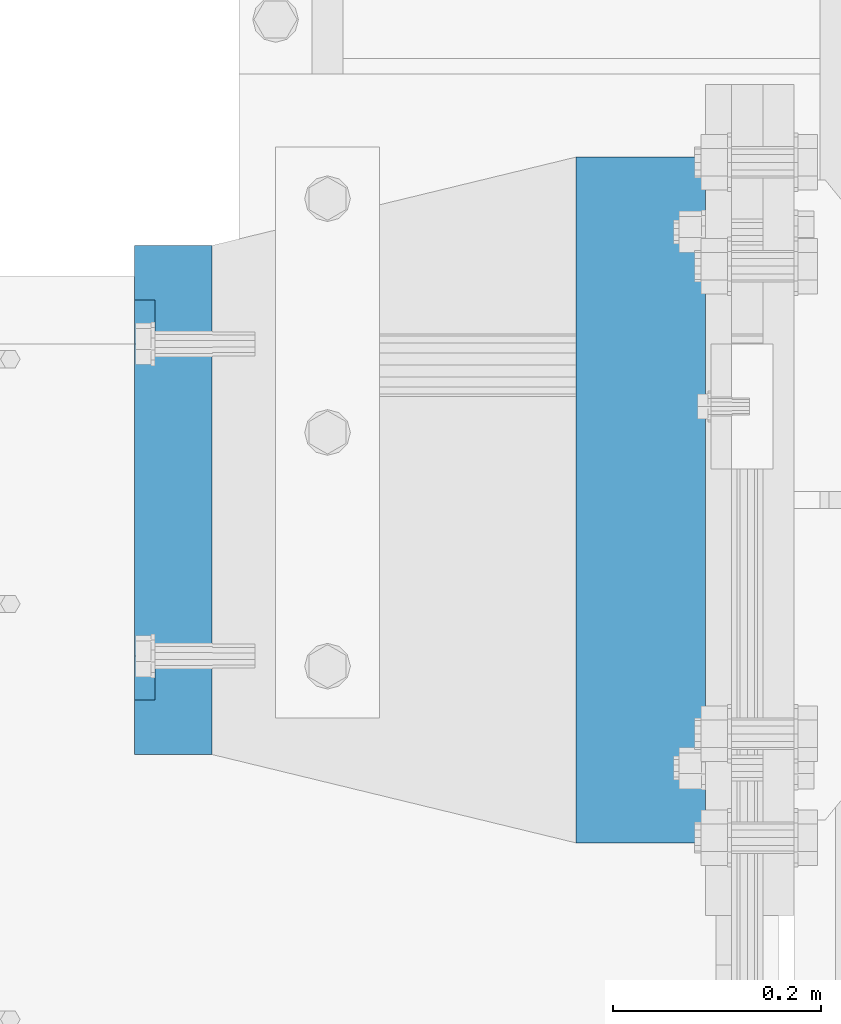
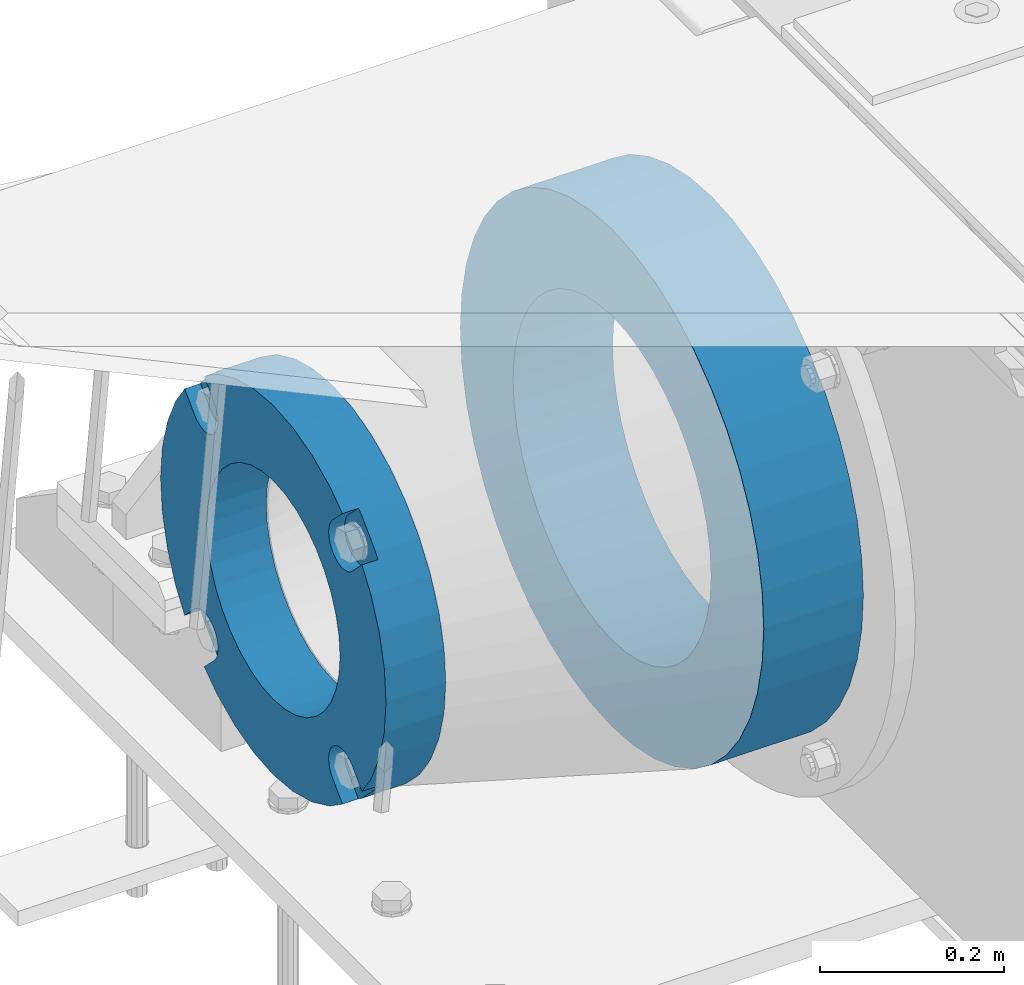
# One storey, part 161 of 270: 2 beams.
"""IFC2X3 building model written with IfcOpenShell, lengths in millimetres."""

from ifc_helpers import new_model, si_unit, frame, origin_with_axes, place, context, subcontext, project, spatial, faceted_brep, material, type_object, element, save


model = new_model("IFC2X3")

# Units and contexts
model_context = context("Model", 3, precision=1e-05, world=origin_with_axes())
body_context = subcontext(model_context, "Body", "Model", "MODEL_VIEW")
ifc_project = project(units=[si_unit("LENGTHUNIT", "METRE", prefix="MILLI"), si_unit("AREAUNIT", "SQUARE_METRE"), si_unit("VOLUMEUNIT", "CUBIC_METRE"), si_unit("MASSUNIT", "GRAM", prefix="KILO"), si_unit("TIMEUNIT", "SECOND"), si_unit("PLANEANGLEUNIT", "RADIAN"), si_unit("SOLIDANGLEUNIT", "STERADIAN"), si_unit("THERMODYNAMICTEMPERATUREUNIT", "DEGREE_CELSIUS"), si_unit("LUMINOUSINTENSITYUNIT", "LUMEN")], contexts=[model_context])

# Site, building, storey
site_placement = place(None, origin_with_axes())
site = spatial("IfcSite", under=ifc_project, at=site_placement, CompositionType="ELEMENT")
building_placement = place(site_placement, origin_with_axes())
building = spatial("IfcBuilding", under=site, at=building_placement, Name="Standard", CompositionType="ELEMENT")
storey_placement = place(building_placement, origin_with_axes())
storey = spatial("IfcBuildingStorey", under=building, at=storey_placement, Name="Undefined", CompositionType="ELEMENT", Elevation=0.0)

# Beams
ifc_material_1 = material(Name="SCN-500-E2")
beam_type_1 = type_object("IfcBeamType", PredefinedType="NOTDEFINED")
beam_1_placement = place(storey_placement, frame((-550.0, -14999.9999985338, -515.0), z_axis=(0.0, 0.0, 1.0), x_axis=(-1.0, 0.0, 0.0)))
element("IfcBeam", 1, at=beam_1_placement, inside=storey, type_object=beam_type_1, material=ifc_material_1, context=body_context, shape_type="Brep", body=[
    faceted_brep([(75.0, 192.717024793295, -150.290616455865), (75.0, 171.473395903973, -129.046987566545), (55.0000000000002, 171.473395903973, -129.046987566545), (55.0000000000002, 192.717024793295, -150.290616455866), (75.0, 167.467485558907, -125.685629673472), (55.0000000000002, 167.467485558907, -125.685629673472), (75.0, 162.938740320598, -123.070957391042), (55.0000000000002, 162.938740320598, -123.070957391042), (75.0, 158.024763821453, -121.282416213469), (55.0000000000002, 158.024763821453, -121.282416213469), (75.0, 152.874864750807, -120.374350059389), (55.0000000000002, 152.874864750807, -120.374350059389), (75.0, 147.645520185946, -120.374350059389), (55.0000000000002, 147.645520185946, -120.374350059389), (75.0, 142.4956211153, -121.282416213469), (55.0000000000002, 142.4956211153, -121.282416213469), (75.0, 137.581644616155, -123.070957391042), (55.0000000000002, 137.581644616155, -123.070957391042), (75.0, 133.052899377846, -125.685629673472), (55.0000000000002, 133.052899377846, -125.685629673472), (75.0, 129.04698903278, -129.046987566545), (55.0000000000002, 129.04698903278, -129.046987566545), (75.0, 125.685631139708, -133.05289791161), (55.0000000000002, 125.685631139708, -133.05289791161), (75.0, 123.070958857277, -137.581643149921), (55.0000000000002, 123.070958857277, -137.581643149921), (75.0, 121.282417679704, -142.495619649066), (55.0000000000002, 121.282417679704, -142.495619649066), (75.0, 120.374351525625, -147.645518719712), (55.0000000000002, 120.374351525625, -147.645518719712), (75.0, 120.374351525625, -152.874863284571), (55.0000000000002, 120.374351525625, -152.874863284571), (75.0, 121.282417679706, -158.024762355217), (55.0000000000002, 121.282417679706, -158.024762355217), (75.0, 123.070958857277, -162.938738854362), (55.0000000000002, 123.070958857277, -162.938738854362), (75.0, 125.685631139708, -167.467484092673), (55.0000000000002, 125.685631139708, -167.467484092673), (75.0, 129.04698903278, -171.473394437738), (55.0000000000002, 129.04698903278, -171.473394437738), (55.0000000000002, 150.290618180639, -192.717023585596), (75.0, 150.290618180637, -192.717023585598), (55.0000000000002, 157.482964373203, -187.68088856415), (55.0000000000002, 187.680888564149, -157.482964373202), (75.0, -192.717023585596, 150.290618180639), (75.0000000000001, -171.4733929715, 129.046987566544), (55.0000000000002, -171.4733929715, 129.046987566544), (55.0000000000002, -192.717023585596, 150.290618180638), (75.0000000000001, -167.467482626435, 125.68562967347), (55.0000000000002, -167.467482626435, 125.68562967347), (75.0000000000001, -162.938737388125, 123.070957391041), (55.0000000000002, -162.938737388125, 123.070957391041), (75.0000000000001, -158.02476088898, 121.282416213468), (55.0000000000002, -158.02476088898, 121.282416213468), (75.0000000000001, -152.874861818334, 120.374350059388), (55.0000000000002, -152.874861818334, 120.374350059388), (75.0000000000001, -147.645517253473, 120.374350059388), (55.0000000000002, -147.645517253473, 120.374350059388), (75.0000000000001, -142.495618182829, 121.282416213468), (55.0000000000002, -142.495618182829, 121.282416213468), (75.0000000000001, -137.581641683682, 123.070957391041), (55.0000000000002, -137.581641683682, 123.070957391041), (75.0000000000001, -133.052896445373, 125.685629673471), (55.0000000000002, -133.052896445373, 125.685629673471), (75.0000000000001, -129.046986100308, 129.046987566544), (55.0000000000002, -129.046986100308, 129.046987566544), (75.0000000000001, -125.685628207235, 133.052897911609), (55.0000000000002, -125.685628207235, 133.052897911609), (75.0000000000001, -123.070955924804, 137.581643149919), (55.0000000000002, -123.070955924804, 137.581643149919), (75.0000000000001, -121.282414747231, 142.495619649065), (55.0000000000002, -121.282414747231, 142.495619649065), (75.0000000000001, -120.374348593152, 147.645518719711), (55.0000000000002, -120.374348593152, 147.645518719711), (75.0000000000001, -120.374348593152, 152.87486328457), (55.0000000000002, -120.374348593152, 152.87486328457), (75.0000000000001, -121.282414747231, 158.024762355216), (55.0000000000002, -121.282414747231, 158.024762355216), (75.0000000000001, -123.070955924804, 162.938738854361), (55.0000000000002, -123.070955924804, 162.938738854361), (75.0000000000001, -125.685628207235, 167.467484092672), (55.0000000000002, -125.685628207235, 167.467484092672), (75.0000000000001, -129.046986100308, 171.473394437737), (55.0000000000002, -129.046986100308, 171.473394437737), (55.0000000000002, -150.290616455866, 192.717024793296), (75.0, -150.290616455866, 192.717024793296), (75.0, 150.290618180637, 192.717023585597), (75.0, 129.04698903278, 171.473394437739), (55.0000000000002, 129.04698903278, 171.473394437739), (55.0000000000002, 150.290618180637, 192.717023585597), (75.0, 125.685631139708, 167.467484092674), (55.0000000000002, 125.685631139708, 167.467484092674), (75.0, 123.070958857277, 162.938738854364), (55.0000000000002, 123.070958857277, 162.938738854364), (75.0, 121.282417679704, 158.024762355218), (55.0000000000002, 121.282417679704, 158.024762355218), (75.0, 120.374351525625, 152.874863284573), (55.0000000000002, 120.374351525625, 152.874863284573), (75.0, 120.374351525625, 147.645518719713), (55.0000000000002, 120.374351525625, 147.645518719713), (75.0, 121.282417679704, 142.495619649067), (55.0000000000002, 121.282417679704, 142.495619649067), (75.0, 123.070958857277, 137.581643149922), (55.0000000000002, 123.070958857277, 137.581643149922), (75.0, 125.685631139708, 133.052897911611), (55.0000000000002, 125.685631139708, 133.052897911611), (75.0, 129.04698903278, 129.046987566546), (55.0000000000002, 129.04698903278, 129.046987566546), (75.0, 133.052899377846, 125.685629673473), (55.0000000000002, 133.052899377846, 125.685629673473), (75.0, 137.581644616155, 123.070957391043), (55.0000000000002, 137.581644616155, 123.070957391043), (75.0, 142.4956211153, 121.282416213471), (55.0000000000002, 142.4956211153, 121.282416213471), (75.0, 147.645520185946, 120.37435005939), (55.0000000000002, 147.645520185946, 120.37435005939), (75.0, 152.874864750807, 120.37435005939), (55.0000000000002, 152.874864750807, 120.37435005939), (75.0000000000001, 158.024763821453, 121.282416213471), (55.0000000000002, 158.024763821453, 121.282416213471), (75.0000000000001, 162.938740320598, 123.070957391043), (55.0000000000002, 162.938740320598, 123.070957391043), (75.0000000000001, 167.467485558907, 125.685629673473), (55.0000000000002, 167.467485558907, 125.685629673473), (75.0000000000001, 171.473395903973, 129.046987566546), (55.0000000000002, 171.473395903973, 129.046987566546), (55.0000000000002, 192.717024793294, 150.290616455866), (75.0, 192.717024793295, 150.290616455867), (0.0, 212.176223927188, -122.5), (0.0, 230.224692092548, -83.7949351147888), (75.0, 230.224692092548, -83.7949351147888), (75.0, 212.176223927188, -122.5), (0.0, 241.277899487992, -42.5438035283978), (75.0, 241.277899487992, -42.5438035283978), (0.0, 245.0, 0.0), (75.0, 245.0, 0.0), (0.0, 241.277899487992, 42.543803528398), (75.0, 241.277899487992, 42.543803528398), (0.0, 230.224692092548, 83.7949351147889), (75.0, 230.224692092548, 83.7949351147889), (0.0, 212.176223927188, 122.5), (75.0, 212.176223927188, 122.5), (0.0, 187.680888564149, 157.482964373202), (55.0000000000002, 187.680888564149, 157.482964373202), (0.0, 157.482964373203, 187.68088856415), (55.0000000000002, 157.482964373203, 187.68088856415), (0.0, 122.5, 212.176223927187), (75.0, 122.5, 212.176223927187), (0.0, 83.794935114789, 230.224692092548), (75.0, 83.794935114789, 230.224692092548), (0.0, 42.5438035283987, 241.277899487991), (75.0, 42.5438035283987, 241.277899487991), (0.0, 0.0, 245.0), (75.0, 0.0, 245.0), (0.0, -42.5438035283987, 241.277899487991), (75.0, -42.5438035283987, 241.277899487991), (0.0, -83.794935114789, 230.224692092548), (75.0, -83.794935114789, 230.224692092548), (0.0, -122.5, 212.176223927187), (75.0, -122.5, 212.176223927187), (0.0, -157.482964373203, 187.68088856415), (55.0000000000002, -157.482964373203, 187.68088856415), (0.0, -187.680888564149, 157.482964373202), (55.0000000000002, -187.680888564149, 157.482964373202), (0.0, -212.176223927188, 122.5), (75.0, -212.176223927188, 122.5), (0.0, -230.224692092548, 83.7949351147888), (75.0, -230.224692092548, 83.7949351147888), (0.0, -241.277899487992, 42.5438035283979), (75.0, -241.277899487992, 42.5438035283979), (0.0, -245.0, 0.0), (75.0, -245.0, 0.0), (0.0, -187.680888564149, -157.482964373202), (0.0, -157.482964373203, -187.68088856415), (55.0000000000002, -157.482964373203, -187.68088856415), (55.0000000000002, -187.680888564149, -157.482964373202), (0.0, 83.794935114789, -230.224692092547), (0.0, 122.5, -212.176223927187), (75.0, 122.5, -212.176223927187), (75.0, 83.794935114789, -230.224692092547), (0.0, 42.5438035283987, -241.277899487991), (75.0, 42.5438035283987, -241.277899487991), (0.0, 0.0, -245.0), (75.0, 0.0, -245.0), (0.0, -42.5438035283987, -241.277899487991), (75.0, -42.5438035283987, -241.277899487991), (0.0, -83.794935114789, -230.224692092548), (75.0, -83.794935114789, -230.224692092548), (0.0, -122.5, -212.176223927187), (75.0, -122.5, -212.176223927187), (75.0, -150.290616455866, -192.717024793296), (55.0000000000002, -150.290616455866, -192.717024793297), (55.0000000000002, -129.046986100308, -171.473394437739), (55.0000000000002, -125.685628207235, -167.467484092674), (55.0000000000002, -123.070955924804, -162.938738854364), (55.0000000000002, -121.282414747233, -158.024762355219), (55.0000000000002, -120.374348593152, -152.874863284573), (55.0000000000002, -120.374348593152, -147.645518719713), (55.0000000000002, -121.282414747233, -142.495619649067), (55.0000000000002, -123.070955924804, -137.581643149922), (55.0000000000002, -125.685628207235, -133.052897911612), (55.0000000000002, -129.046986100308, -129.046987566547), (55.0000000000002, -133.052896445373, -125.685629673473), (55.0000000000002, -137.581641683682, -123.070957391043), (55.0000000000002, -142.495618182827, -121.282416213471), (55.0000000000002, -147.645517253473, -120.374350059391), (55.0000000000002, -152.874861818334, -120.374350059391), (55.0000000000002, -158.02476088898, -121.282416213471), (55.0000000000002, -162.938737388125, -123.070957391043), (55.0000000000002, -167.467482626435, -125.685629673473), (55.0000000000002, -171.4733929715, -129.046987566546), (55.0000000000002, -192.717023585594, -150.29061818064), (75.0, -129.046986100308, -171.473394437739), (75.0, -125.685628207235, -167.467484092674), (75.0, -123.070955924804, -162.938738854364), (75.0, -121.282414747233, -158.024762355219), (75.0, -120.374348593152, -152.874863284573), (75.0, -120.374348593152, -147.645518719713), (75.0, -121.282414747233, -142.495619649067), (75.0, -123.070955924804, -137.581643149922), (75.0, -125.685628207235, -133.052897911612), (75.0, -129.046986100308, -129.046987566547), (75.0, -133.052896445373, -125.685629673473), (75.0, -137.581641683682, -123.070957391043), (75.0, -142.495618182827, -121.282416213471), (75.0, -147.645517253473, -120.374350059391), (75.0, -152.874861818334, -120.374350059391), (75.0, -158.02476088898, -121.282416213471), (75.0, -162.938737388125, -123.070957391043), (75.0, -167.467482626435, -125.685629673473), (75.0, -171.4733929715, -129.046987566546), (75.0, -192.717023585594, -150.290618180641), (75.0, -212.176223927187, -122.5), (0.0, -212.176223927187, -122.5), (0.0, -230.224692092548, -83.794935114789), (75.0, -230.224692092548, -83.794935114789), (0.0, -241.277899487992, -42.5438035283979), (75.0, -241.277899487992, -42.5438035283979), (0.0, 187.680888564149, -157.482964373202), (0.0, 157.482964373203, -187.68088856415), (0.0, -142.797124186771, -25.1789857617049), (0.0, -136.255430013956, -49.592920782222), (0.0, -125.573683548744, -72.5), (0.0, -111.076444252252, -93.2042034045483), (0.0, -93.204203404548, -111.076444252252), (0.0, -72.5, -125.573683548744), (0.0, -49.5929207822228, -136.255430013957), (0.0, -25.1789857617041, -142.79712418677), (0.0, 0.0, -145.0), (0.0, 25.1789857617041, -142.79712418677), (0.0, 49.5929207822228, -136.255430013957), (0.0, 72.5, -125.573683548744), (0.0, 93.204203404548, -111.076444252252), (0.0, 111.076444252252, -93.2042034045483), (0.0, 125.573683548744, -72.5), (0.0, 136.255430013956, -49.592920782222), (0.0, 142.797124186771, -25.178985761705), (0.0, 145.0, 0.0), (0.0, 142.797124186771, 25.1789857617048), (0.0, 136.255430013956, 49.5929207822219), (0.0, 125.573683548744, 72.4999999999999), (0.0, 111.076444252252, 93.2042034045482), (0.0, 93.204203404548, 111.076444252252), (0.0, 72.5, 125.573683548744), (0.0, 49.5929207822228, 136.255430013957), (0.0, 25.1789857617041, 142.79712418677), (0.0, 0.0, 145.0), (0.0, -25.1789857617041, 142.79712418677), (0.0, -49.5929207822228, 136.255430013957), (0.0, -72.5, 125.573683548744), (0.0, -93.204203404548, 111.076444252252), (0.0, -111.076444252252, 93.2042034045483), (0.0, -125.573683548744, 72.5000000000001), (0.0, -136.255430013956, 49.5929207822221), (0.0, -142.797124186771, 25.1789857617049), (0.0, -145.0, 0.0), (75.0, -145.0, 0.0), (75.0, -142.797124186771, -25.1789857617049), (75.0, -136.255430013956, -49.592920782222), (75.0, -125.573683548744, -72.5), (75.0, -111.076444252252, -93.2042034045483), (75.0, -93.204203404548, -111.076444252252), (75.0, -72.5, -125.573683548744), (75.0, -49.5929207822228, -136.255430013957), (75.0, -25.1789857617041, -142.79712418677), (75.0, 0.0, -145.0), (75.0, 25.1789857617041, -142.79712418677), (75.0, 49.5929207822228, -136.255430013957), (75.0, 72.5, -125.573683548744), (75.0, 93.204203404548, -111.076444252252), (75.0, 111.076444252252, -93.2042034045483), (75.0, 125.573683548744, -72.5), (75.0, 136.255430013956, -49.592920782222), (75.0, 142.797124186771, -25.178985761705), (75.0, 145.0, 0.0), (75.0, 142.797124186771, 25.1789857617048), (75.0, 136.255430013956, 49.5929207822219), (75.0, 125.573683548744, 72.4999999999999), (75.0, 111.076444252252, 93.2042034045482), (75.0, 93.204203404548, 111.076444252252), (75.0, 72.5, 125.573683548744), (75.0, 49.5929207822228, 136.255430013957), (75.0, 25.1789857617041, 142.79712418677), (75.0, 0.0, 145.0), (75.0, -25.1789857617041, 142.79712418677), (75.0, -49.5929207822228, 136.255430013957), (75.0, -72.5, 125.573683548744), (75.0, -93.204203404548, 111.076444252252), (75.0, -111.076444252252, 93.2042034045483), (75.0, -125.573683548744, 72.5000000000001), (75.0, -136.255430013956, 49.5929207822221), (75.0, -142.797124186771, 25.1789857617049)], [[[0, 1, 2, 3]], [[4, 5, 2, 1]], [[6, 7, 5, 4]], [[8, 9, 7, 6]], [[10, 11, 9, 8]], [[12, 13, 11, 10]], [[14, 15, 13, 12]], [[16, 17, 15, 14]], [[18, 19, 17, 16]], [[20, 21, 19, 18]], [[22, 23, 21, 20]], [[24, 25, 23, 22]], [[26, 27, 25, 24]], [[28, 29, 27, 26]], [[30, 31, 29, 28]], [[32, 33, 31, 30]], [[34, 35, 33, 32]], [[36, 37, 35, 34]], [[38, 39, 37, 36]], [[40, 39, 38, 41]], [[42, 43, 3, 2, 5, 7, 9, 11, 13, 15, 17, 19, 21, 23, 25, 27, 29, 31, 33, 35, 37, 39, 40]], [[44, 45, 46, 47]], [[48, 49, 46, 45]], [[50, 51, 49, 48]], [[52, 53, 51, 50]], [[54, 55, 53, 52]], [[56, 57, 55, 54]], [[58, 59, 57, 56]], [[60, 61, 59, 58]], [[62, 63, 61, 60]], [[64, 65, 63, 62]], [[66, 67, 65, 64]], [[68, 69, 67, 66]], [[70, 71, 69, 68]], [[72, 73, 71, 70]], [[74, 75, 73, 72]], [[76, 77, 75, 74]], [[78, 79, 77, 76]], [[80, 81, 79, 78]], [[82, 83, 81, 80]], [[84, 83, 82, 85]], [[86, 87, 88, 89]], [[90, 91, 88, 87]], [[92, 93, 91, 90]], [[94, 95, 93, 92]], [[96, 97, 95, 94]], [[98, 99, 97, 96]], [[100, 101, 99, 98]], [[102, 103, 101, 100]], [[104, 105, 103, 102]], [[106, 107, 105, 104]], [[108, 109, 107, 106]], [[110, 111, 109, 108]], [[112, 113, 111, 110]], [[114, 115, 113, 112]], [[116, 117, 115, 114]], [[118, 119, 117, 116]], [[120, 121, 119, 118]], [[122, 123, 121, 120]], [[124, 125, 123, 122]], [[126, 125, 124, 127]], [[128, 129, 130, 131]], [[129, 132, 133, 130]], [[132, 134, 135, 133]], [[134, 136, 137, 135]], [[136, 138, 139, 137]], [[138, 140, 141, 139]], [[127, 141, 140, 142, 143, 126]], [[142, 144, 145, 143]], [[89, 88, 91, 93, 95, 97, 99, 101, 103, 105, 107, 109, 111, 113, 115, 117, 119, 121, 123, 125, 126, 143, 145]], [[144, 146, 147, 86, 89, 145]], [[146, 148, 149, 147]], [[148, 150, 151, 149]], [[150, 152, 153, 151]], [[152, 154, 155, 153]], [[154, 156, 157, 155]], [[156, 158, 159, 157]], [[85, 159, 158, 160, 161, 84]], [[160, 162, 163, 161]], [[47, 46, 49, 51, 53, 55, 57, 59, 61, 63, 65, 67, 69, 71, 73, 75, 77, 79, 81, 83, 84, 161, 163]], [[162, 164, 165, 44, 47, 163]], [[164, 166, 167, 165]], [[166, 168, 169, 167]], [[168, 170, 171, 169]], [[172, 173, 174, 175]], [[176, 177, 178, 179]], [[180, 176, 179, 181]], [[182, 180, 181, 183]], [[184, 182, 183, 185]], [[186, 184, 185, 187]], [[188, 186, 187, 189]], [[173, 188, 189, 190, 191, 174]], [[175, 174, 191, 192, 193, 194, 195, 196, 197, 198, 199, 200, 201, 202, 203, 204, 205, 206, 207, 208, 209, 210, 211]], [[190, 212, 192, 191]], [[213, 193, 192, 212]], [[214, 194, 193, 213]], [[215, 195, 194, 214]], [[216, 196, 195, 215]], [[217, 197, 196, 216]], [[218, 198, 197, 217]], [[219, 199, 198, 218]], [[220, 200, 199, 219]], [[221, 201, 200, 220]], [[222, 202, 201, 221]], [[223, 203, 202, 222]], [[224, 204, 203, 223]], [[225, 205, 204, 224]], [[226, 206, 205, 225]], [[227, 207, 206, 226]], [[228, 208, 207, 227]], [[229, 209, 208, 228]], [[230, 210, 209, 229]], [[211, 210, 230, 231]], [[232, 233, 172, 175, 211, 231]], [[234, 233, 232, 235]], [[236, 234, 235, 237]], [[170, 236, 237, 171]], [[168, 166, 164, 162, 160, 158, 156, 154, 152, 150, 148, 146, 144, 142, 140, 138, 136, 134, 132, 129, 128, 238, 239, 177, 176, 180, 182, 184, 186, 188, 173, 172, 233, 234, 236, 170], [240, 241, 242, 243, 244, 245, 246, 247, 248, 249, 250, 251, 252, 253, 254, 255, 256, 257, 258, 259, 260, 261, 262, 263, 264, 265, 266, 267, 268, 269, 270, 271, 272, 273, 274, 275]], [[240, 275, 276, 277]], [[241, 240, 277, 278]], [[242, 241, 278, 279]], [[243, 242, 279, 280]], [[244, 243, 280, 281]], [[245, 244, 281, 282]], [[246, 245, 282, 283]], [[247, 246, 283, 284]], [[248, 247, 284, 285]], [[249, 248, 285, 286]], [[250, 249, 286, 287]], [[251, 250, 287, 288]], [[252, 251, 288, 289]], [[253, 252, 289, 290]], [[254, 253, 290, 291]], [[255, 254, 291, 292]], [[256, 255, 292, 293]], [[257, 256, 293, 294]], [[258, 257, 294, 295]], [[259, 258, 295, 296]], [[260, 259, 296, 297]], [[261, 260, 297, 298]], [[262, 261, 298, 299]], [[263, 262, 299, 300]], [[264, 263, 300, 301]], [[265, 264, 301, 302]], [[266, 265, 302, 303]], [[267, 266, 303, 304]], [[268, 267, 304, 305]], [[269, 268, 305, 306]], [[270, 269, 306, 307]], [[271, 270, 307, 308]], [[272, 271, 308, 309]], [[273, 272, 309, 310]], [[274, 273, 310, 311]], [[275, 274, 311, 276]], [[24, 22, 20, 18, 16, 14, 12, 10, 8, 6, 4, 1, 0, 131, 130, 133, 135, 137, 139, 141, 127, 124, 122, 120, 118, 116, 114, 112, 110, 108, 106, 104, 102, 100, 98, 96, 94, 92, 90, 87, 86, 147, 149, 151, 153, 155, 157, 159, 85, 82, 80, 78, 76, 74, 72, 70, 68, 66, 64, 62, 60, 58, 56, 54, 52, 50, 48, 45, 44, 165, 167, 169, 171, 237, 235, 232, 231, 230, 229, 228, 227, 226, 225, 224, 223, 222, 221, 220, 219, 218, 217, 216, 215, 214, 213, 212, 190, 189, 187, 185, 183, 181, 179, 178, 41, 38, 36, 34, 32, 30, 28, 26], [310, 309, 308, 307, 306, 305, 304, 303, 302, 301, 300, 299, 298, 297, 296, 295, 294, 293, 292, 291, 290, 289, 288, 287, 286, 285, 284, 283, 282, 281, 280, 279, 278, 277, 276, 311]], [[238, 128, 131, 0, 3, 43]], [[239, 238, 43, 42]], [[178, 177, 239, 42, 40, 41]]]),
])
ifc_material_2 = material(Name="STEEL/S355N")
beam_type_2 = type_object("IfcBeamType", PredefinedType="NOTDEFINED")
beam_2_placement = place(storey_placement, frame((-74.999999999991, -15000.0, -515.0), z_axis=(0.0, 0.0, 1.0), x_axis=(-1.0, 0.0, 0.0)))
element("IfcBeam", 2, at=beam_2_placement, inside=storey, type_object=beam_type_2, material=ifc_material_2, context=body_context, shape_type="Brep", body=[
    faceted_brep([(0.0, -215.0, 0.0), (0.0, -212.811610004401, 30.5976902287563), (125.0, -212.811610004401, 30.5976902287563), (125.0, -215.0, 0.0), (0.0, -206.290989327117, 60.5724997209074), (125.0, -206.290989327117, 60.5724997209074), (0.0, -195.570879001221, 89.3142277954056), (125.0, -195.570879001221, 89.3142277954056), (0.0, -180.869509558705, 116.237775752953), (125.0, -180.869509558705, 116.237775752953), (0.0, -162.486158486165, 140.795057798236), (125.0, -162.486158486165, 140.795057798236), (0.0, -140.795057798236, 162.486158486165), (125.0, -140.795057798236, 162.486158486165), (0.0, -116.237775752954, 180.869509558704), (125.0, -116.237775752954, 180.869509558704), (0.0, -89.3142277954048, 195.570879001222), (125.0, -89.3142277954048, 195.570879001222), (0.0, -60.5724997209072, 206.290989327117), (125.0, -60.5724997209072, 206.290989327117), (0.0, -30.5976902287566, 212.811610004401), (125.0, -30.5976902287566, 212.811610004401), (0.0, 0.0, 215.0), (125.0, 0.0, 215.0), (0.0, 30.5976902287566, 212.811610004401), (125.0, 30.5976902287566, 212.811610004401), (0.0, 60.5724997209072, 206.290989327117), (125.0, 60.5724997209072, 206.290989327117), (0.0, 89.3142277954048, 195.570879001221), (125.0, 89.3142277954048, 195.570879001221), (0.0, 116.237775752954, 180.869509558704), (125.0, 116.237775752954, 180.869509558704), (0.0, 140.795057798236, 162.486158486165), (125.0, 140.795057798236, 162.486158486165), (0.0, 162.486158486165, 140.795057798236), (125.0, 162.486158486165, 140.795057798236), (0.0, 180.869509558705, 116.237775752953), (125.0, 180.869509558705, 116.237775752953), (0.0, 195.570879001221, 89.3142277954056), (125.0, 195.570879001221, 89.3142277954056), (0.0, 206.290989327117, 60.5724997209073), (125.0, 206.290989327117, 60.5724997209073), (0.0, 212.811610004401, 30.5976902287563), (125.0, 212.811610004401, 30.5976902287563), (0.0, 215.0, 0.0), (125.0, 215.0, 0.0), (0.0, 212.811610004401, -30.5976902287563), (125.0, 212.811610004401, -30.5976902287563), (0.0, 206.290989327117, -60.5724997209073), (125.0, 206.290989327117, -60.5724997209073), (0.0, 195.570879001221, -89.3142277954056), (125.0, 195.570879001221, -89.3142277954056), (0.0, 180.869509558705, -116.237775752954), (125.0, 180.869509558705, -116.237775752954), (0.0, 162.486158486165, -140.795057798236), (125.0, 162.486158486165, -140.795057798236), (0.0, 140.795057798236, -162.486158486166), (125.0, 140.795057798236, -162.486158486166), (0.0, 116.237775752954, -180.869509558704), (125.0, 116.237775752954, -180.869509558704), (0.0, 89.3142277954048, -195.570879001221), (125.0, 89.3142277954048, -195.570879001221), (0.0, 60.5724997209072, -206.290989327117), (125.0, 60.5724997209072, -206.290989327117), (0.0, 30.5976902287566, -212.811610004401), (125.0, 30.5976902287566, -212.811610004401), (0.0, 0.0, -215.0), (125.0, 0.0, -215.0), (0.0, -30.5976902287566, -212.811610004401), (125.0, -30.5976902287566, -212.811610004401), (0.0, -60.5724997209072, -206.290989327117), (125.0, -60.5724997209072, -206.290989327117), (0.0, -89.3142277954048, -195.570879001221), (125.0, -89.3142277954048, -195.570879001221), (0.0, -116.237775752954, -180.869509558704), (125.0, -116.237775752954, -180.869509558704), (0.0, -140.795057798236, -162.486158486166), (125.0, -140.795057798236, -162.486158486166), (0.0, -162.486158486165, -140.795057798236), (125.0, -162.486158486165, -140.795057798236), (0.0, -180.869509558705, -116.237775752953), (125.0, -180.869509558705, -116.237775752953), (0.0, -195.570879001221, -89.3142277954056), (125.0, -195.570879001221, -89.3142277954056), (0.0, -206.290989327117, -60.5724997209073), (125.0, -206.290989327117, -60.5724997209073), (0.0, -212.811610004401, -30.5976902287563), (125.0, -212.811610004401, -30.5976902287563), (0.0, -330.0, 0.0), (0.0, -326.641075820708, -46.9638966301842), (125.0, -326.641075820708, -46.9638966301842), (125.0, -330.0, 0.0), (0.0, -316.632681292784, -92.9717437576718), (125.0, -316.632681292784, -92.9717437576718), (0.0, -300.178558466991, -137.086954290623), (125.0, -300.178558466991, -137.086954290623), (0.0, -277.613665834289, -178.411469760347), (125.0, -277.613665834289, -178.411469760347), (0.0, -249.397359536906, -216.104042201944), (125.0, -249.397359536906, -216.104042201944), (0.0, -216.104042201943, -249.397359536905), (125.0, -216.104042201943, -249.397359536905), (0.0, -178.411469760347, -277.61366583429), (125.0, -178.411469760347, -277.61366583429), (0.0, -137.086954290622, -300.178558466991), (125.0, -137.086954290622, -300.178558466991), (0.0, -92.971743757671, -316.632681292784), (125.0, -92.971743757671, -316.632681292784), (0.0, -46.9638966301845, -326.641075820708), (125.0, -46.9638966301845, -326.641075820708), (0.0, 0.0, -330.0), (125.0, 0.0, -330.0), (0.0, 46.9638966301845, -326.641075820708), (125.0, 46.9638966301845, -326.641075820708), (0.0, 92.971743757671, -316.632681292784), (125.0, 92.971743757671, -316.632681292784), (0.0, 137.086954290622, -300.178558466991), (125.0, 137.086954290622, -300.178558466991), (0.0, 178.411469760347, -277.61366583429), (125.0, 178.411469760347, -277.61366583429), (0.0, 216.104042201943, -249.397359536905), (125.0, 216.104042201943, -249.397359536905), (0.0, 249.397359536906, -216.104042201944), (125.0, 249.397359536906, -216.104042201944), (0.0, 277.613665834289, -178.411469760347), (125.0, 277.613665834289, -178.411469760347), (0.0, 300.178558466991, -137.086954290623), (125.0, 300.178558466991, -137.086954290623), (0.0, 316.632681292784, -92.9717437576717), (125.0, 316.632681292784, -92.9717437576717), (0.0, 326.641075820708, -46.9638966301841), (125.0, 326.641075820708, -46.9638966301841), (0.0, 330.0, 0.0), (125.0, 330.0, 0.0), (0.0, 326.641075820708, 46.9638966301841), (125.0, 326.641075820708, 46.9638966301841), (0.0, 316.632681292784, 92.9717437576718), (125.0, 316.632681292784, 92.9717437576718), (0.0, 300.178558466991, 137.086954290622), (125.0, 300.178558466991, 137.086954290622), (0.0, 277.613665834289, 178.411469760347), (125.0, 277.613665834289, 178.411469760347), (0.0, 249.397359536904, 216.104042201944), (125.0, 249.397359536904, 216.104042201944), (0.0, 216.104042201943, 249.397359536905), (125.0, 216.104042201943, 249.397359536905), (0.0, 178.411469760347, 277.61366583429), (125.0, 178.411469760347, 277.61366583429), (0.0, 137.086954290622, 300.178558466991), (125.0, 137.086954290622, 300.178558466991), (0.0, 92.971743757671, 316.632681292784), (125.0, 92.971743757671, 316.632681292784), (0.0, 46.9638966301845, 326.641075820708), (125.0, 46.9638966301845, 326.641075820708), (0.0, 0.0, 330.0), (125.0, 0.0, 330.0), (0.0, -46.9638966301845, 326.641075820708), (125.0, -46.9638966301845, 326.641075820708), (0.0, -92.971743757671, 316.632681292784), (125.0, -92.971743757671, 316.632681292784), (0.0, -137.086954290622, 300.178558466991), (125.0, -137.086954290622, 300.178558466991), (0.0, -178.411469760347, 277.61366583429), (125.0, -178.411469760347, 277.61366583429), (0.0, -216.104042201943, 249.397359536905), (125.0, -216.104042201943, 249.397359536905), (0.0, -249.397359536906, 216.104042201944), (125.0, -249.397359536906, 216.104042201944), (0.0, -277.613665834289, 178.411469760347), (125.0, -277.613665834289, 178.411469760347), (0.0, -300.178558466991, 137.086954290623), (125.0, -300.178558466991, 137.086954290623), (0.0, -316.632681292784, 92.9717437576718), (125.0, -316.632681292784, 92.9717437576718), (0.0, -326.641075820708, 46.9638966301841), (125.0, -326.641075820708, 46.9638966301841)], [[[0, 1, 2, 3]], [[1, 4, 5, 2]], [[4, 6, 7, 5]], [[6, 8, 9, 7]], [[8, 10, 11, 9]], [[10, 12, 13, 11]], [[12, 14, 15, 13]], [[14, 16, 17, 15]], [[16, 18, 19, 17]], [[18, 20, 21, 19]], [[20, 22, 23, 21]], [[22, 24, 25, 23]], [[24, 26, 27, 25]], [[26, 28, 29, 27]], [[28, 30, 31, 29]], [[30, 32, 33, 31]], [[32, 34, 35, 33]], [[34, 36, 37, 35]], [[36, 38, 39, 37]], [[38, 40, 41, 39]], [[40, 42, 43, 41]], [[42, 44, 45, 43]], [[44, 46, 47, 45]], [[46, 48, 49, 47]], [[48, 50, 51, 49]], [[50, 52, 53, 51]], [[52, 54, 55, 53]], [[54, 56, 57, 55]], [[56, 58, 59, 57]], [[58, 60, 61, 59]], [[60, 62, 63, 61]], [[62, 64, 65, 63]], [[64, 66, 67, 65]], [[66, 68, 69, 67]], [[68, 70, 71, 69]], [[70, 72, 73, 71]], [[72, 74, 75, 73]], [[74, 76, 77, 75]], [[76, 78, 79, 77]], [[78, 80, 81, 79]], [[80, 82, 83, 81]], [[82, 84, 85, 83]], [[84, 86, 87, 85]], [[86, 0, 3, 87]], [[88, 89, 90, 91]], [[89, 92, 93, 90]], [[92, 94, 95, 93]], [[94, 96, 97, 95]], [[96, 98, 99, 97]], [[98, 100, 101, 99]], [[100, 102, 103, 101]], [[102, 104, 105, 103]], [[104, 106, 107, 105]], [[106, 108, 109, 107]], [[108, 110, 111, 109]], [[110, 112, 113, 111]], [[112, 114, 115, 113]], [[114, 116, 117, 115]], [[116, 118, 119, 117]], [[118, 120, 121, 119]], [[120, 122, 123, 121]], [[122, 124, 125, 123]], [[124, 126, 127, 125]], [[126, 128, 129, 127]], [[128, 130, 131, 129]], [[130, 132, 133, 131]], [[132, 134, 135, 133]], [[134, 136, 137, 135]], [[136, 138, 139, 137]], [[138, 140, 141, 139]], [[140, 142, 143, 141]], [[142, 144, 145, 143]], [[144, 146, 147, 145]], [[146, 148, 149, 147]], [[148, 150, 151, 149]], [[150, 152, 153, 151]], [[152, 154, 155, 153]], [[154, 156, 157, 155]], [[156, 158, 159, 157]], [[158, 160, 161, 159]], [[160, 162, 163, 161]], [[162, 164, 165, 163]], [[164, 166, 167, 165]], [[166, 168, 169, 167]], [[168, 170, 171, 169]], [[170, 172, 173, 171]], [[172, 174, 175, 173]], [[174, 88, 91, 175]], [[93, 95, 97, 99, 101, 103, 105, 107, 109, 111, 113, 115, 117, 119, 121, 123, 125, 127, 129, 131, 133, 135, 137, 139, 141, 143, 145, 147, 149, 151, 153, 155, 157, 159, 161, 163, 165, 167, 169, 171, 173, 175, 91, 90], [5, 7, 9, 11, 13, 15, 17, 19, 21, 23, 25, 27, 29, 31, 33, 35, 37, 39, 41, 43, 45, 47, 49, 51, 53, 55, 57, 59, 61, 63, 65, 67, 69, 71, 73, 75, 77, 79, 81, 83, 85, 87, 3, 2]], [[174, 172, 170, 168, 166, 164, 162, 160, 158, 156, 154, 152, 150, 148, 146, 144, 142, 140, 138, 136, 134, 132, 130, 128, 126, 124, 122, 120, 118, 116, 114, 112, 110, 108, 106, 104, 102, 100, 98, 96, 94, 92, 89, 88], [86, 84, 82, 80, 78, 76, 74, 72, 70, 68, 66, 64, 62, 60, 58, 56, 54, 52, 50, 48, 46, 44, 42, 40, 38, 36, 34, 32, 30, 28, 26, 24, 22, 20, 18, 16, 14, 12, 10, 8, 6, 4, 1, 0]]]),
])

save(model, "model.ifc")
